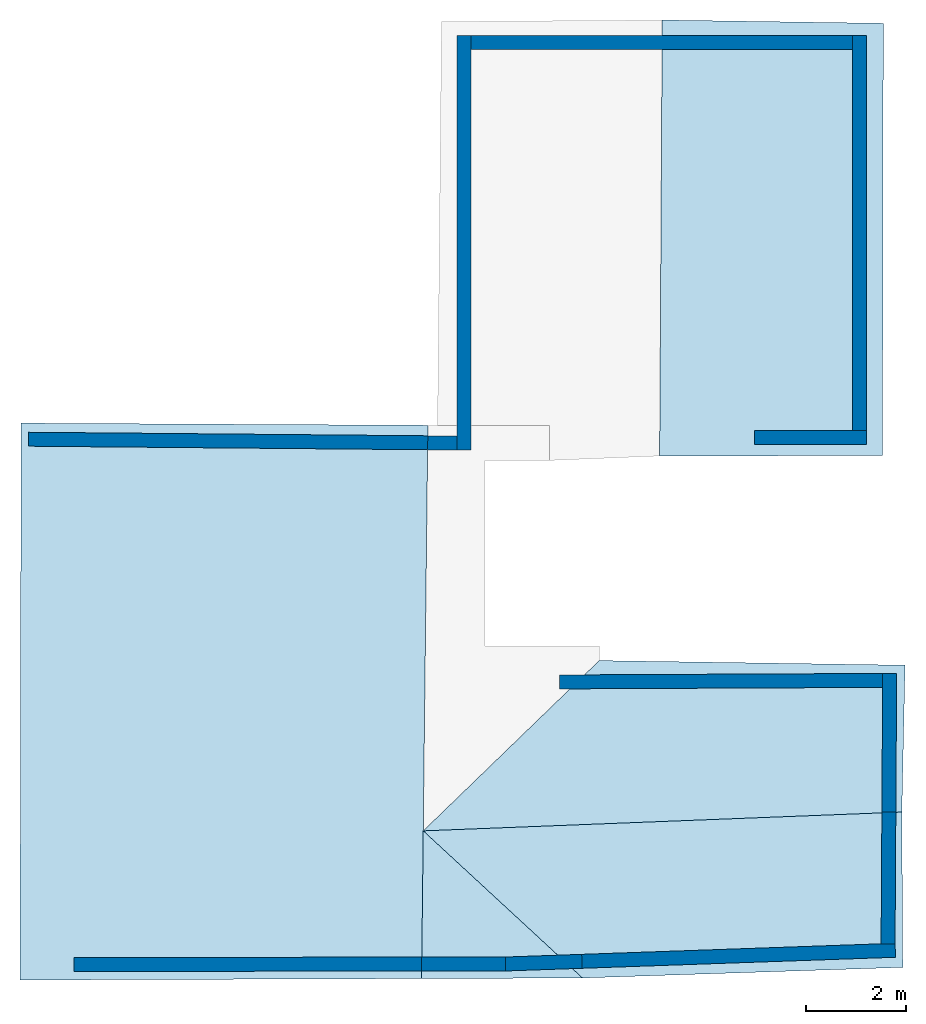
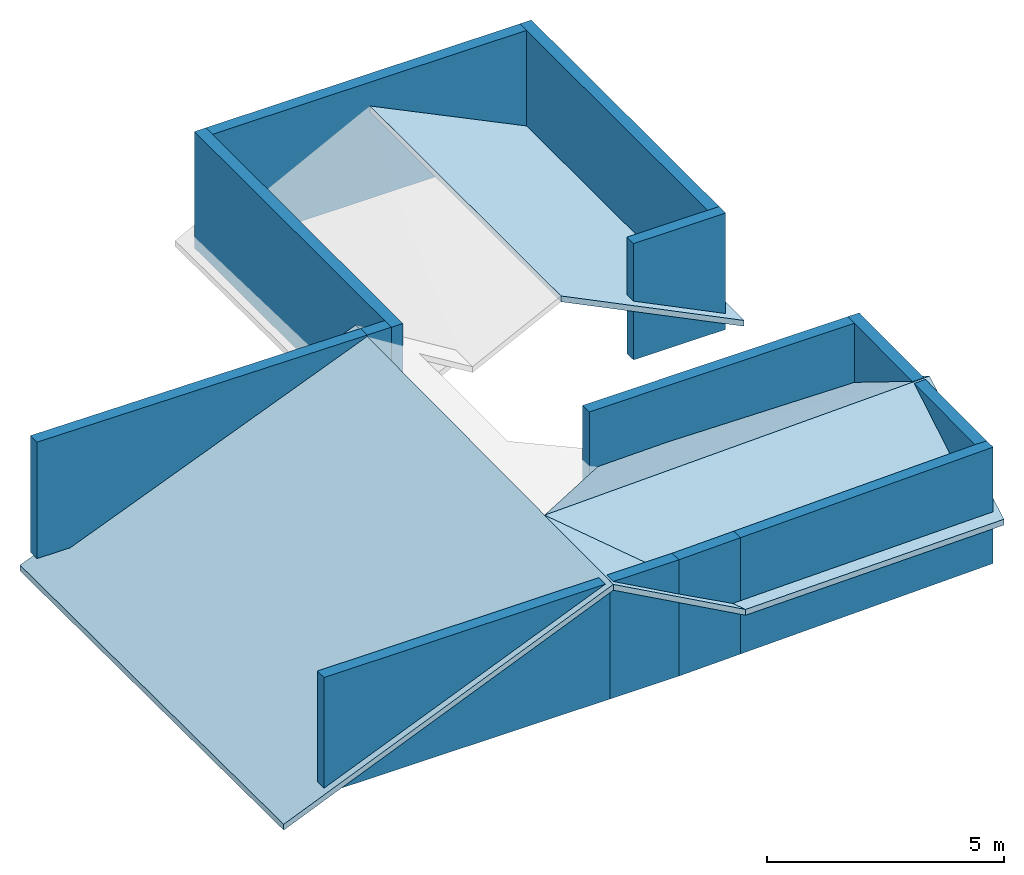
# One storey, part 1 of 2: 13 walls, 5 slabs.
"""IFC4 building model written with IfcOpenShell, lengths in metres."""

from ifc_helpers import new_model, entity, si_unit, converted_unit, frame, frame_2d, origin_with_axes, place, context, subcontext, project, spatial, indexed_curve, outline, extrude, polygons, material, layer, layer_set, layer_usage, type_object, element, save


model = new_model("IFC4")

# Units and contexts
model_context = context("Model", 3, precision=1e-05, world=origin_with_axes())
plan_context = context("Plan", 2, precision=1e-05, world=frame_2d((0.0, 0.0, 0.0), x_axis=(1.0, 0.0, 0.0)))
body_context = subcontext(model_context, "Body", "Model", "MODEL_VIEW")
ifc_project = project(units=[converted_unit("PLANEANGLEUNIT", "degree", entity("IfcReal", 0.0174532925199433), si_unit("PLANEANGLEUNIT", "RADIAN"), dimensions=[0, 0, 0, 0, 0, 0, 0]), si_unit("AREAUNIT", "SQUARE_METRE"), si_unit("VOLUMEUNIT", "CUBIC_METRE"), si_unit("LENGTHUNIT", "METRE")], contexts=[model_context, plan_context])

# Site, building, storey
site_placement = place(None, origin_with_axes())
site = spatial("IfcSite", under=ifc_project, at=site_placement)
building_placement = place(site_placement, origin_with_axes())
building = spatial("IfcBuilding", under=site, at=building_placement, Name="Building")
storey_placement = place(building_placement, frame((0.0, 0.0, 3.0), z_axis=(0.0, 0.0, 1.0), x_axis=(1.0, 0.0, 0.0)))
storey = spatial("IfcBuildingStorey", under=building, at=storey_placement, Name="Dachgeschoss")

# Slabs
slab_1_placement = place(storey_placement, frame((0.138327658176422, 11.9685554504395, -0.0325007438659668), z_axis=(-0.389843016862869, 1.06302975311223e-08, 0.920881330966949), x_axis=(0.920881330966949, -5.23788585837792e-08, 0.389843016862869)))
element("IfcSlab", 1, at=slab_1_placement, inside=storey, Name="roof_wohnen", PredefinedType="ROOF", context=body_context, shape_type="Tessellation", body=[
    polygons([(0.139375194907188, -0.0453592203557491, -0.456899970769882), (0.15936766564846, -11.2182168960571, -0.357028633356094), (0.0808987393975258, -0.0453592240810394, -0.595032215118408), (0.100891202688217, -11.2182168960571, -0.495160847902298), (8.96628284454346, -0.0885668694972992, -0.54577898979187), (8.88335037231445, -11.1898832321167, -0.415635466575623), (8.82487392425537, -11.1898832321167, -0.553767681121826), (8.90780639648438, -0.0885668694972992, -0.683911144733429)], [[[1, 5, 8, 3]], [[1, 3, 4, 2]], [[7, 6, 2, 4]], [[6, 7, 8, 5]], [[1, 6, 5]], [[3, 7, 4]], [[1, 2, 6]], [[3, 8, 7]]]),
])
slab_2_placement = place(storey_placement, frame((7.51337957382202, 18.4299716949463, 3.13837957382202), z_axis=(0.0, 0.0, 1.0), x_axis=(1.0, 0.0, 0.0)))
element("IfcSlab", 2, at=slab_2_placement, inside=storey, PredefinedType="ROOF", context=body_context, shape_type="Tessellation", body=[
    polygons([(0.967490494251251, -17.6513004302979, -0.0905194282531738), (4.19703483581543, -17.6393585205078, -1.87382221221924), (1.00142824649811, -14.6873569488525, -0.113885402679443), (1.00142824649811, -14.6873569488525, -0.263885408639908), (0.967490494251251, -17.6513004302979, -0.240519434213638), (4.19703483581543, -17.6393585205078, -2.02382230758667)], [[[3, 1, 2]], [[4, 6, 5]], [[3, 2, 6, 4]], [[2, 1, 5, 6]], [[1, 3, 4, 5]]]),
])
slab_3_placement = place(storey_placement, frame((11.5073595046997, 19.0338859558105, -0.612094879150391), z_axis=(0.0, 0.0, 1.0), x_axis=(1.0, 0.0, 0.0)))
element("IfcSlab", 3, at=slab_3_placement, inside=storey, Name="dach_n", PredefinedType="ROOF", context=body_context, shape_type="Tessellation", body=[
    polygons([(0.20305597782135, -18.2432727813721, 1.87665224075317), (6.62885904312134, -18.0298824310303, 1.82354259490967), (-2.99255204200745, -15.2912702560425, 3.63658905029297), (6.6104941368103, -14.9145994186401, 3.63154697418213), (-2.99255204200745, -15.2912702560425, 3.48658895492554), (0.20305597782135, -18.2432727813721, 1.72665226459503), (6.62885904312134, -18.0298824310303, 1.67354261875153), (6.6104941368103, -14.9145994186401, 3.4815468788147)], [[[1, 4, 2]], [[6, 8, 5]], [[2, 4, 8, 7]], [[3, 1, 6, 5]], [[4, 3, 5, 8]], [[1, 2, 7, 6]], [[1, 3, 4]], [[6, 7, 8]]]),
])
slab_4_placement = place(storey_placement, frame((11.5073595046997, 19.0338859558105, -0.612094879150391), z_axis=(0.0, 0.0, 1.0), x_axis=(1.0, 0.0, 0.0)))
element("IfcSlab", 4, at=slab_4_placement, inside=storey, Name="dach_s", PredefinedType="ROOF", context=body_context, shape_type="Tessellation", body=[
    polygons([(-2.99255204200745, -15.2912702560425, 3.63658905029297), (6.61049318313599, -14.9145994186401, 3.63154697418213), (0.53916323184967, -11.8741445541382, 1.83055698871613), (6.67501163482666, -11.9667654037476, 1.80503046512604), (0.53916323184967, -11.8741445541382, 1.68055701255798), (-2.99255204200745, -15.2912702560425, 3.48658895492554), (6.61049318313599, -14.9145994186401, 3.4815468788147), (6.67501163482666, -11.9667654037476, 1.6550304889679)], [[[3, 2, 1]], [[7, 5, 6]], [[2, 4, 8, 7]], [[3, 6, 5]], [[4, 3, 5, 8]], [[1, 2, 7, 6]], [[3, 4, 2]], [[7, 8, 5]], [[3, 1, 6]]]),
])
slab_5_placement = place(storey_placement, frame((14.0933465957642, 19.4814624786377, 1.75806331634521), z_axis=(0.83547306060791, 6.05244423468321e-08, 0.54953134059906), x_axis=(0.54953134059906, 1.12253204065382e-07, -0.83547306060791)))
element("IfcSlab", 5, at=slab_5_placement, inside=storey, Name="dach_sw", PredefinedType="ROOF", context=body_context, shape_type="Tessellation", body=[
    polygons([(-1.04153060913086, -8.217942237854, -0.316155582666397), (3.25821256637573, -8.2083625793457, 2.20982432365417), (-0.953627169132233, 0.529778599739075, -0.311261177062988), (3.28126811981201, 0.463787794113159, 2.21388936042786), (-0.980952382087708, -2.60569453239441, -5.8044319152832), (-0.828306198120117, 0.529778599739075, -0.393690884113312), (-0.916209638118744, -8.217942237854, -0.398585289716721), (3.38353371620178, -8.2083625793457, 2.1273946762085), (3.40658903121948, 0.463787794113159, 2.13145971298218)], [[[1, 4, 2]], [[7, 9, 6]], [[2, 4, 9, 8]], [[3, 1, 7, 6]], [[4, 3, 6, 9]], [[1, 2, 8, 7]], [[1, 3, 4]], [[7, 8, 9]]]),
])

# Walls
ifc_material = material(Name="aussenwand_280_material")
ifc_layer = layer(ifc_material, 0.280000001192093)
ifc_layer_set = layer_set([ifc_layer])
ifc_layer_usage_1 = layer_usage(ifc_layer_set, "AXIS2", "POSITIVE", 0.0)
wall_type = type_object("IfcWallType", Name="aussenwand_280", PredefinedType="STANDARD", material=ifc_layer_set)
wall_1_placement = place(storey_placement, frame((9.18882751464844, 19.7012138366699, -2.38418579101563e-07), z_axis=(0.0, 0.0, 1.0), x_axis=(-1.62920684942947e-07, -1.0, 0.0)))
element("IfcWall", 6, at=wall_1_placement, inside=storey, type_object=wall_type, material=ifc_layer_usage_1, Name="Wall", PredefinedType="NOTDEFINED", context=body_context, shape_type="SweptSolid", body=[
    extrude(outline(indexed_curve([(0.0, 0.0), (0.0, 0.280000001192093), (8.31982420442171, 0.280000001192093), (8.31982420442171, 0.0), (0.0, 0.0)], self_intersect=False)), origin_with_axes(), (0.0, 0.0, 1.0), 3.0),
])
ifc_layer_usage_2 = layer_usage(ifc_layer_set, "AXIS2", "POSITIVE", 0.0)
wall_2_placement = place(storey_placement, frame((1.50885987281799, 0.922550857067108, -2.38418579101563e-07), z_axis=(0.0, 0.0, 1.0), x_axis=(0.999999582767487, 0.000923240790143609, 0.0)))
element("IfcWall", 7, at=wall_2_placement, inside=storey, type_object=wall_type, material=ifc_layer_usage_2, Name="Wall", PredefinedType="NOTDEFINED", context=body_context, shape_type="SweptSolid", body=[
    extrude(outline(indexed_curve([(0.0, 0.0), (0.0, 0.280000001192093), (6.97187437102741, 0.280000001192093), (6.97187437102741, 0.0), (0.0, 0.0)], self_intersect=False)), origin_with_axes(), (0.0, 0.0, 1.0), 3.0),
])
ifc_layer_usage_3 = layer_usage(ifc_layer_set, "AXIS2", "POSITIVE", 0.0)
wall_3_placement = place(storey_placement, frame((10.1700124740601, 0.931393384933472, -2.38418579101563e-07), z_axis=(0.0, 0.0, 1.0), x_axis=(0.999382197856903, 0.0351415351033211, 0.0)))
element("IfcWall", 8, at=wall_3_placement, inside=storey, type_object=wall_type, material=ifc_layer_usage_3, Name="Wall", PredefinedType="NOTDEFINED", context=body_context, shape_type="SweptSolid", body=[
    extrude(outline(indexed_curve([(0.0, 0.0), (0.0, 0.280000001192093), (1.53450472655644, 0.280000001192093), (1.53450472655644, 0.0), (0.0, 0.0)], self_intersect=False)), origin_with_axes(), (0.0, 0.0, 1.0), 3.0),
])
ifc_layer_usage_4 = layer_usage(ifc_layer_set, "AXIS2", "POSITIVE", 0.0)
wall_4_placement = place(storey_placement, frame((17.7329654693604, 6.90121555328369, -2.38418579101563e-07), z_axis=(0.0, 0.0, 1.0), x_axis=(-0.999989092350006, -0.00467242300510406, 0.0)))
element("IfcWall", 9, at=wall_4_placement, inside=storey, type_object=wall_type, material=ifc_layer_usage_4, Name="Wall", PredefinedType="NOTDEFINED", context=body_context, shape_type="SweptSolid", body=[
    extrude(outline(indexed_curve([(0.0, 0.0), (0.0, 0.280000001192093), (6.4844628440617, 0.280000001192093), (6.4844628440617, 0.0), (0.0, 0.0)], self_intersect=False)), origin_with_axes(), (0.0, 0.0, 1.0), 3.0),
])
ifc_layer_usage_5 = layer_usage(ifc_layer_set, "AXIS2", "POSITIVE", 0.0)
wall_5_placement = place(storey_placement, frame((9.19131374359131, 11.6638669967651, -2.38418579101563e-07), z_axis=(0.0, 0.0, 1.0), x_axis=(-0.999960541725159, 0.00888374913483858, 0.0)))
element("IfcWall", 10, at=wall_5_placement, inside=storey, type_object=wall_type, material=ifc_layer_usage_5, Name="Wall", PredefinedType="NOTDEFINED", context=body_context, shape_type="SweptSolid", body=[
    extrude(outline(indexed_curve([(0.0, 0.0), (0.0, 0.280000001192093), (0.585232937038386, 0.280000001192093), (0.585232937038386, 0.0), (0.0, 0.0)], self_intersect=False)), origin_with_axes(), (0.0, 0.0, 1.0), 3.0),
])
ifc_layer_usage_6 = layer_usage(ifc_layer_set, "AXIS2", "POSITIVE", 0.0)
wall_6_placement = place(storey_placement, frame((9.46882724761963, 19.4212131500244, -2.38418579101563e-07), z_axis=(0.0, 0.0, 1.0), x_axis=(1.0, 0.0, 0.0)))
element("IfcWall", 11, at=wall_6_placement, inside=storey, type_object=wall_type, material=ifc_layer_usage_6, Name="Wall", PredefinedType="NOTDEFINED", context=body_context, shape_type="SweptSolid", body=[
    extrude(outline(indexed_curve([(0.0, 0.0), (0.0, 0.280000001192093), (7.65666477870406, 0.280000001192093), (7.65666477870406, 0.0), (0.0, 0.0)], self_intersect=False)), origin_with_axes(), (0.0, 0.0, 1.0), 3.0),
])
ifc_layer_usage_7 = layer_usage(ifc_layer_set, "AXIS2", "POSITIVE", 0.0)
wall_7_placement = place(storey_placement, frame((17.732982635498, 6.90418434143066, -2.38418579101563e-07), z_axis=(0.0, 0.0, 1.0), x_axis=(-0.00592900207266212, -0.999982416629791, 0.0)))
element("IfcWall", 12, at=wall_7_placement, inside=storey, type_object=wall_type, material=ifc_layer_usage_7, Name="Wall", PredefinedType="NOTDEFINED", context=body_context, shape_type="SweptSolid", body=[
    extrude(outline(indexed_curve([(0.0, 0.0), (0.0, 0.280000001192093), (2.78256681753973, 0.280000001192093), (2.78256681753973, 0.0), (0.0, 0.0)], self_intersect=False)), origin_with_axes(), (0.0, 0.0, 1.0), 3.0),
])
ifc_layer_usage_8 = layer_usage(ifc_layer_set, "AXIS2", "POSITIVE", 0.0)
wall_8_placement = place(storey_placement, frame((15.1564960479736, 11.4919033050537, -2.38418579101563e-07), z_axis=(0.0, 0.0, 1.0), x_axis=(1.0, 0.0, 0.0)))
element("IfcWall", 13, at=wall_8_placement, inside=storey, type_object=wall_type, material=ifc_layer_usage_8, Name="Wall", PredefinedType="NOTDEFINED", context=body_context, shape_type="SweptSolid", body=[
    extrude(outline(indexed_curve([(0.0, 0.0), (0.0, 0.280000001192093), (2.24899481466534, 0.280000001192093), (2.24899481466534, 0.0), (0.0, 0.0)], self_intersect=False)), origin_with_axes(), (0.0, 0.0, 1.0), 3.0),
])
ifc_layer_usage_9 = layer_usage(ifc_layer_set, "AXIS2", "POSITIVE", 0.0)
wall_9_placement = place(storey_placement, frame((17.1254920959473, 19.7012138366699, -2.38418579101563e-07), z_axis=(0.0, 0.0, 1.0), x_axis=(-1.62920684942947e-07, -1.0, 0.0)))
element("IfcWall", 14, at=wall_9_placement, inside=storey, type_object=wall_type, material=ifc_layer_usage_9, Name="Wall", PredefinedType="NOTDEFINED", context=body_context, shape_type="SweptSolid", body=[
    extrude(outline(indexed_curve([(0.0, 0.0), (0.0, 0.280000001192093), (7.92931081694632, 0.280000001192093), (7.92931081694632, 0.0), (0.0, 0.0)], self_intersect=False)), origin_with_axes(), (0.0, 0.0, 1.0), 3.0),
])
ifc_layer_usage_10 = layer_usage(ifc_layer_set, "AXIS2", "POSITIVE", 0.0)
wall_10_placement = place(storey_placement, frame((8.4807300567627, 0.929833590984344, -2.38418579101563e-07), z_axis=(0.0, 0.0, 1.0), x_axis=(0.999999582767487, 0.000923240790143609, 0.0)))
element("IfcWall", 15, at=wall_10_placement, inside=storey, type_object=wall_type, material=ifc_layer_usage_10, Name="Wall", PredefinedType="NOTDEFINED", context=body_context, shape_type="SweptSolid", body=[
    extrude(outline(indexed_curve([(0.0, 0.0), (0.0, 0.280000001192093), (1.68927835094324, 0.280000001192093), (1.68927835094324, 0.0), (0.0, 0.0)], self_intersect=False)), origin_with_axes(), (0.0, 0.0, 1.0), 3.0),
])
ifc_layer_usage_11 = layer_usage(ifc_layer_set, "AXIS2", "POSITIVE", 0.0)
wall_11_placement = place(storey_placement, frame((11.7035694122314, 0.985318243503571, -2.38418579101563e-07), z_axis=(0.0, 0.0, 1.0), x_axis=(0.999382138252258, 0.0351415351033211, 0.0)))
element("IfcWall", 16, at=wall_11_placement, inside=storey, type_object=wall_type, material=ifc_layer_usage_11, Name="Wall", PredefinedType="NOTDEFINED", context=body_context, shape_type="SweptSolid", body=[
    extrude(outline(indexed_curve([(0.0, 0.0), (0.0, 0.280000001192093), (6.29101780503812, 0.280000001192093), (6.29101780503812, 0.0), (0.0, 0.0)], self_intersect=False)), origin_with_axes(), (0.0, 0.0, 1.0), 3.0),
])
ifc_layer_usage_12 = layer_usage(ifc_layer_set, "AXIS2", "POSITIVE", 0.0)
wall_12_placement = place(storey_placement, frame((17.7164840698242, 4.121666431427, -2.38418579101563e-07), z_axis=(0.0, 0.0, 1.0), x_axis=(-0.00592900207266212, -0.999982416629791, 0.0)))
element("IfcWall", 17, at=wall_12_placement, inside=storey, type_object=wall_type, material=ifc_layer_usage_12, Name="Wall", PredefinedType="NOTDEFINED", context=body_context, shape_type="SweptSolid", body=[
    extrude(outline(indexed_curve([(0.0, 0.0), (0.0, 0.280000001192093), (2.64533971893712, 0.280000001192093), (2.64533971893712, 0.0), (0.0, 0.0)], self_intersect=False)), origin_with_axes(), (0.0, 0.0, 1.0), 3.0),
])
ifc_layer_usage_13 = layer_usage(ifc_layer_set, "AXIS2", "POSITIVE", 0.0)
wall_13_placement = place(storey_placement, frame((8.60610389709473, 11.6690664291382, -0.0010533332824707), z_axis=(0.0, 0.0, 1.0), x_axis=(-0.999960541725159, 0.00888374913483858, 0.0)))
element("IfcWall", 18, at=wall_13_placement, inside=storey, type_object=wall_type, material=ifc_layer_usage_13, Name="Wall", PredefinedType="NOTDEFINED", context=body_context, shape_type="SweptSolid", body=[
    extrude(outline(indexed_curve([(0.0, 0.0), (0.0, 0.280000001192093), (8.01390124085017, 0.280000001192093), (8.01390124085017, 0.0), (0.0, 0.0)], self_intersect=False)), origin_with_axes(), (0.0, 0.0, 1.0), 3.0),
])

save(model, "model.ifc")
